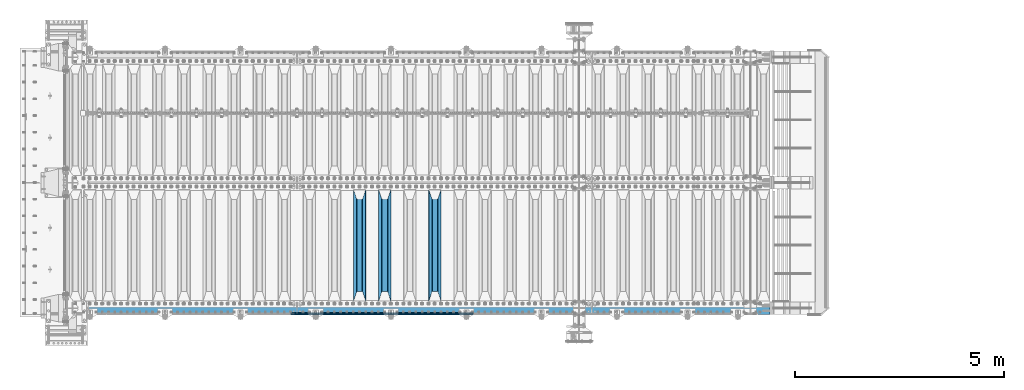
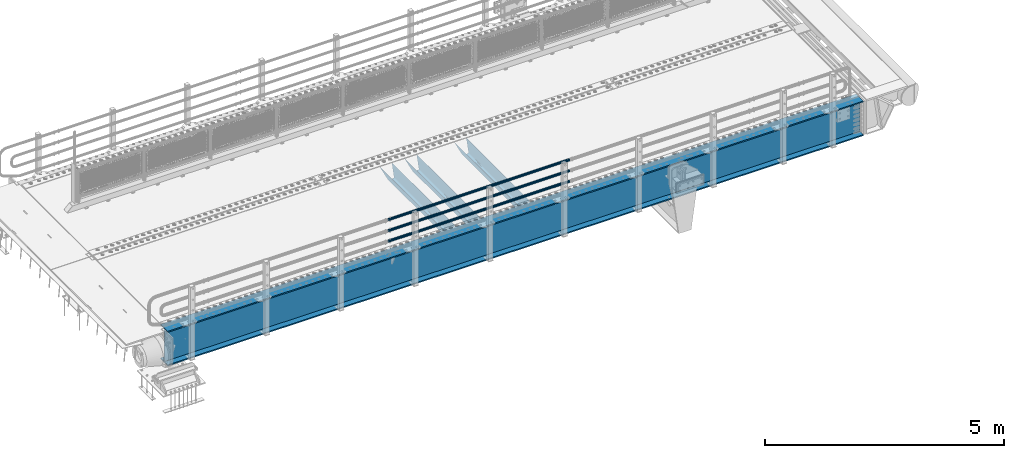
# One storey, part 98 of 208: 7 beams.
"""IFC2X3 building model written with IfcOpenShell, lengths in millimetres."""

from ifc_helpers import new_model, si_unit, frame, origin_with_axes, place, context, subcontext, project, spatial, faceted_brep, material, type_object, element, save


model = new_model("IFC2X3")

# Units and contexts
model_context = context("Model", 3, precision=1e-05, world=origin_with_axes())
body_context = subcontext(model_context, "Body", "Model", "MODEL_VIEW")
ifc_project = project(units=[si_unit("LENGTHUNIT", "METRE", prefix="MILLI"), si_unit("AREAUNIT", "SQUARE_METRE"), si_unit("VOLUMEUNIT", "CUBIC_METRE"), si_unit("MASSUNIT", "GRAM", prefix="KILO"), si_unit("TIMEUNIT", "SECOND"), si_unit("PLANEANGLEUNIT", "RADIAN"), si_unit("SOLIDANGLEUNIT", "STERADIAN"), si_unit("THERMODYNAMICTEMPERATUREUNIT", "DEGREE_CELSIUS"), si_unit("LUMINOUSINTENSITYUNIT", "LUMEN")], contexts=[model_context])

# Site, building, storey
site_placement = place(None, origin_with_axes())
site = spatial("IfcSite", under=ifc_project, at=site_placement, CompositionType="ELEMENT")
building_placement = place(site_placement, origin_with_axes())
building = spatial("IfcBuilding", under=site, at=building_placement, Name="Standard", CompositionType="ELEMENT")
storey_placement = place(building_placement, origin_with_axes())
storey = spatial("IfcBuildingStorey", under=building, at=storey_placement, Name="Undefined", CompositionType="ELEMENT", Elevation=0.0)

# Beams
ifc_material_1 = material(Name="STEEL/S355N")
beam_type_1 = type_object("IfcBeamType", PredefinedType="NOTDEFINED")
beam_1_placement = place(storey_placement, frame((-33650.0, 175.0, -115.0), z_axis=(0.0, 0.0, 1.0), x_axis=(0.0, 1.0, 0.0)))
element("IfcBeam", 1, at=beam_1_placement, inside=storey, type_object=beam_type_1, material=ifc_material_1, context=body_context, shape_type="Brep", body=[
    faceted_brep([(0.0, 150.0, 115.0), (0.0, 143.689999999999, 115.0), (2650.00000000297, 143.689999999999, 115.0), (2650.00000000297, 150.0, 115.0), (2650.00000000297, 142.059565218402, 110.0000000031), (2650.00000000297, 148.369565218403, 110.0000000031), (2441.90079219208, -80.1103600731112, -98.0992078077845), (2437.7588105432, -77.5672621345584, -102.241189456673), (2434.06523489746, -74.4080125315522, -105.934765102404), (2430.91086095089, -70.710272125576, -109.089139048974), (2428.37322971128, -66.5649389910068, -111.626770288588), (2426.51472138055, -62.0739139532889, -113.485278619323), (2425.38102192091, -57.3475956567672, -114.618978078955), (2424.99999999987, -52.5021667386536, -115.0), (2424.99999999987, 52.5021667386536, -115.0), (2425.38102192091, 57.3475956567672, -114.618978078955), (2426.51472138055, 62.0739139532889, -113.485278619323), (2428.37322971128, 66.5649389910068, -111.626770288588), (2430.91086095089, 70.710272125576, -109.089139048974), (2434.06523489746, 74.4080125315522, -105.934765102404), (2437.7588105432, 77.5672621345584, -102.241189456673), (2441.90079219208, 80.1103600731112, -98.0992078077846), (2446.38936140511, 81.9747917625791, -93.6106385947584), (2448.24948500409, 76.2713538057251, -91.7505149957729), (2444.62967112262, 74.76777986261, -95.3703288772456), (2441.28936334126, 72.7168944282894, -98.710636658607), (2438.31067330438, 70.1691124903846, -101.689326695487), (2435.76682334747, 67.1870637758839, -104.233176652398), (2433.72034654133, 63.8440531834895, -106.279653458539), (2432.22154950041, 60.222258798236, -107.778450499454), (2431.30727574265, 56.4107117849089, -108.692724257221), (2430.99999999987, 52.5031078186876, -109.0), (2430.99999999987, -52.5031078186876, -109.0), (2431.30727574265, -56.4107117849089, -108.692724257221), (2432.22154950041, -60.222258798236, -107.778450499454), (2433.72034654133, -63.8440531834895, -106.279653458539), (2435.76682334747, -67.1870637758839, -104.233176652398), (2438.31067330438, -70.1691124903846, -101.689326695487), (2441.28936334126, -72.7168944282894, -98.7106366586071), (2444.62967112262, -74.76777986261, -95.3703288772457), (2448.24948500409, -76.2713538057251, -91.7505149957729), (2650.00000000297, -142.059565218402, 110.0000000031), (2650.00000000297, -148.369565218403, 110.0000000031), (2446.38936140511, -81.9747917625791, -93.6106385947584), (2650.00000000297, -143.689999999999, 115.0), (2650.00000000297, -150.0, 115.0), (0.0, -143.689999999999, 115.0), (0.0, -150.0, 115.0), (0.0, -148.369565218261, 110.000000002663), (203.610638597421, -81.9747917625791, -93.6106385947584), (208.099207810448, -80.1103600731112, -98.0992078077845), (212.241189459336, -77.5672621345584, -102.241189456673), (215.934765105067, -74.4080125315522, -105.934765102404), (219.089139051637, -70.710272125576, -109.089139048974), (221.626770291251, -66.5649389910068, -111.626770288588), (223.485278621986, -62.0739139532889, -113.485278619323), (224.618978081618, -57.3475956567672, -114.618978078955), (225.000000002663, -52.5021667386536, -115.0), (225.000000002663, 52.5021667386536, -115.0), (224.618978081618, 57.3475956567672, -114.618978078955), (223.485278621986, 62.0739139532889, -113.485278619323), (221.626770291251, 66.5649389910068, -111.626770288588), (219.089139051637, 70.710272125576, -109.089139048974), (215.934765105067, 74.4080125315522, -105.934765102404), (212.241189459336, 77.5672621345584, -102.241189456673), (208.099207810448, 80.1103600731112, -98.0992078077846), (203.610638597421, 81.9747917625791, -93.6106385947584), (0.0, 148.369565218261, 110.000000002663), (0.0, 142.05956521826, 110.000000002663), (201.750514998436, 76.2713538057251, -91.7505149957729), (205.370328879908, 74.76777986261, -95.3703288772456), (208.71063666127, 72.7168944282894, -98.710636658607), (211.68932669815, 70.1691124903846, -101.689326695487), (214.233176655061, 67.1870637758839, -104.233176652398), (216.279653461202, 63.8440531834895, -106.279653458539), (217.778450502116, 60.222258798236, -107.778450499454), (218.692724259884, 56.4107117849089, -108.692724257221), (219.000000002663, 52.5031078186876, -109.0), (219.000000002663, -52.5031078186876, -109.0), (218.692724259884, -56.4107117849089, -108.692724257221), (217.778450502116, -60.222258798236, -107.778450499454), (216.279653461202, -63.8440531834895, -106.279653458539), (214.233176655061, -67.1870637758839, -104.233176652398), (211.68932669815, -70.1691124903846, -101.689326695487), (208.71063666127, -72.7168944282894, -98.7106366586071), (205.370328879908, -74.76777986261, -95.3703288772457), (201.750514998436, -76.2713538057251, -91.7505149957729), (0.0, -142.05956521826, 110.000000002663)], [[[0, 1, 2, 3]], [[3, 2, 4, 5]], [[6, 7, 8, 9, 10, 11, 12, 13, 14, 15, 16, 17, 18, 19, 20, 21, 22, 5, 4, 23, 24, 25, 26, 27, 28, 29, 30, 31, 32, 33, 34, 35, 36, 37, 38, 39, 40, 41, 42, 43]], [[44, 45, 42, 41]], [[46, 47, 45, 44]], [[43, 42, 45, 47, 48, 49]], [[6, 43, 49, 50]], [[7, 6, 50, 51]], [[8, 7, 51, 52]], [[9, 8, 52, 53]], [[10, 9, 53, 54]], [[11, 10, 54, 55]], [[12, 11, 55, 56]], [[13, 12, 56, 57]], [[14, 13, 57, 58]], [[15, 14, 58, 59]], [[16, 15, 59, 60]], [[17, 16, 60, 61]], [[18, 17, 61, 62]], [[19, 18, 62, 63]], [[20, 19, 63, 64]], [[21, 20, 64, 65]], [[22, 21, 65, 66]], [[0, 3, 5, 22, 66, 67]], [[1, 0, 67, 68]], [[23, 4, 2, 1, 68, 69]], [[24, 23, 69, 70]], [[25, 24, 70, 71]], [[26, 25, 71, 72]], [[27, 26, 72, 73]], [[28, 27, 73, 74]], [[29, 28, 74, 75]], [[30, 29, 75, 76]], [[31, 30, 76, 77]], [[32, 31, 77, 78]], [[33, 32, 78, 79]], [[34, 33, 79, 80]], [[35, 34, 80, 81]], [[36, 35, 81, 82]], [[37, 36, 82, 83]], [[38, 37, 83, 84]], [[39, 38, 84, 85]], [[40, 39, 85, 86]], [[46, 44, 41, 40, 86, 87]], [[47, 46, 87, 48]], [[86, 85, 84, 83, 82, 81, 80, 79, 78, 77, 76, 75, 74, 73, 72, 71, 70, 69, 68, 67, 66, 65, 64, 63, 62, 61, 60, 59, 58, 57, 56, 55, 54, 53, 52, 51, 50, 49, 48, 87]]]),
])
beam_2_placement = place(storey_placement, frame((-34850.0, 175.0, -115.0), z_axis=(0.0, 0.0, 1.0), x_axis=(0.0, 1.0, 0.0)))
element("IfcBeam", 2, at=beam_2_placement, inside=storey, type_object=beam_type_1, material=ifc_material_1, context=body_context, shape_type="Brep", body=[
    faceted_brep([(0.0, 150.0, 115.0), (0.0, 143.689999999999, 115.0), (2650.00000000297, 143.689999999999, 115.0), (2650.00000000297, 150.0, 115.0), (2650.00000000297, 142.059565218402, 110.0000000031), (2650.00000000297, 148.369565218403, 110.0000000031), (2441.90079219208, -80.1103600731112, -98.0992078077845), (2437.7588105432, -77.5672621345584, -102.241189456673), (2434.06523489746, -74.4080125315522, -105.934765102404), (2430.91086095089, -70.710272125576, -109.089139048974), (2428.37322971128, -66.5649389910068, -111.626770288588), (2426.51472138055, -62.0739139532889, -113.485278619323), (2425.38102192091, -57.3475956567672, -114.618978078955), (2424.99999999987, -52.5021667386536, -115.0), (2424.99999999987, 52.5021667386536, -115.0), (2425.38102192091, 57.3475956567672, -114.618978078955), (2426.51472138055, 62.0739139532889, -113.485278619323), (2428.37322971128, 66.5649389910068, -111.626770288588), (2430.91086095089, 70.710272125576, -109.089139048974), (2434.06523489746, 74.4080125315522, -105.934765102404), (2437.7588105432, 77.5672621345584, -102.241189456673), (2441.90079219208, 80.1103600731112, -98.0992078077846), (2446.38936140511, 81.9747917625791, -93.6106385947584), (2448.24948500409, 76.2713538057251, -91.7505149957729), (2444.62967112262, 74.76777986261, -95.3703288772456), (2441.28936334126, 72.7168944282894, -98.710636658607), (2438.31067330438, 70.1691124903846, -101.689326695487), (2435.76682334747, 67.1870637758839, -104.233176652398), (2433.72034654133, 63.8440531834895, -106.279653458539), (2432.22154950041, 60.222258798236, -107.778450499454), (2431.30727574265, 56.4107117849089, -108.692724257221), (2430.99999999987, 52.5031078186876, -109.0), (2430.99999999987, -52.5031078186876, -109.0), (2431.30727574265, -56.4107117849089, -108.692724257221), (2432.22154950041, -60.222258798236, -107.778450499454), (2433.72034654133, -63.8440531834895, -106.279653458539), (2435.76682334747, -67.1870637758839, -104.233176652398), (2438.31067330438, -70.1691124903846, -101.689326695487), (2441.28936334126, -72.7168944282894, -98.7106366586071), (2444.62967112262, -74.76777986261, -95.3703288772457), (2448.24948500409, -76.2713538057251, -91.7505149957729), (2650.00000000297, -142.059565218402, 110.0000000031), (2650.00000000297, -148.369565218403, 110.0000000031), (2446.38936140511, -81.9747917625791, -93.6106385947584), (2650.00000000297, -143.689999999999, 115.0), (2650.00000000297, -150.0, 115.0), (0.0, -143.689999999999, 115.0), (0.0, -150.0, 115.0), (0.0, -148.369565218261, 110.000000002663), (203.610638597421, -81.9747917625791, -93.6106385947584), (208.099207810448, -80.1103600731112, -98.0992078077845), (212.241189459336, -77.5672621345584, -102.241189456673), (215.934765105067, -74.4080125315522, -105.934765102404), (219.089139051637, -70.710272125576, -109.089139048974), (221.626770291251, -66.5649389910068, -111.626770288588), (223.485278621986, -62.0739139532889, -113.485278619323), (224.618978081618, -57.3475956567672, -114.618978078955), (225.000000002663, -52.5021667386536, -115.0), (225.000000002663, 52.5021667386536, -115.0), (224.618978081618, 57.3475956567672, -114.618978078955), (223.485278621986, 62.0739139532889, -113.485278619323), (221.626770291251, 66.5649389910068, -111.626770288588), (219.089139051637, 70.710272125576, -109.089139048974), (215.934765105067, 74.4080125315522, -105.934765102404), (212.241189459336, 77.5672621345584, -102.241189456673), (208.099207810448, 80.1103600731112, -98.0992078077846), (203.610638597421, 81.9747917625791, -93.6106385947584), (0.0, 148.369565218261, 110.000000002663), (0.0, 142.05956521826, 110.000000002663), (201.750514998436, 76.2713538057251, -91.7505149957729), (205.370328879908, 74.76777986261, -95.3703288772456), (208.71063666127, 72.7168944282894, -98.710636658607), (211.68932669815, 70.1691124903846, -101.689326695487), (214.233176655061, 67.1870637758839, -104.233176652398), (216.279653461202, 63.8440531834895, -106.279653458539), (217.778450502116, 60.222258798236, -107.778450499454), (218.692724259884, 56.4107117849089, -108.692724257221), (219.000000002663, 52.5031078186876, -109.0), (219.000000002663, -52.5031078186876, -109.0), (218.692724259884, -56.4107117849089, -108.692724257221), (217.778450502116, -60.222258798236, -107.778450499454), (216.279653461202, -63.8440531834895, -106.279653458539), (214.233176655061, -67.1870637758839, -104.233176652398), (211.68932669815, -70.1691124903846, -101.689326695487), (208.71063666127, -72.7168944282894, -98.7106366586071), (205.370328879908, -74.76777986261, -95.3703288772457), (201.750514998436, -76.2713538057251, -91.7505149957729), (0.0, -142.05956521826, 110.000000002663)], [[[0, 1, 2, 3]], [[3, 2, 4, 5]], [[6, 7, 8, 9, 10, 11, 12, 13, 14, 15, 16, 17, 18, 19, 20, 21, 22, 5, 4, 23, 24, 25, 26, 27, 28, 29, 30, 31, 32, 33, 34, 35, 36, 37, 38, 39, 40, 41, 42, 43]], [[44, 45, 42, 41]], [[46, 47, 45, 44]], [[43, 42, 45, 47, 48, 49]], [[6, 43, 49, 50]], [[7, 6, 50, 51]], [[8, 7, 51, 52]], [[9, 8, 52, 53]], [[10, 9, 53, 54]], [[11, 10, 54, 55]], [[12, 11, 55, 56]], [[13, 12, 56, 57]], [[14, 13, 57, 58]], [[15, 14, 58, 59]], [[16, 15, 59, 60]], [[17, 16, 60, 61]], [[18, 17, 61, 62]], [[19, 18, 62, 63]], [[20, 19, 63, 64]], [[21, 20, 64, 65]], [[22, 21, 65, 66]], [[0, 3, 5, 22, 66, 67]], [[1, 0, 67, 68]], [[23, 4, 2, 1, 68, 69]], [[24, 23, 69, 70]], [[25, 24, 70, 71]], [[26, 25, 71, 72]], [[27, 26, 72, 73]], [[28, 27, 73, 74]], [[29, 28, 74, 75]], [[30, 29, 75, 76]], [[31, 30, 76, 77]], [[32, 31, 77, 78]], [[33, 32, 78, 79]], [[34, 33, 79, 80]], [[35, 34, 80, 81]], [[36, 35, 81, 82]], [[37, 36, 82, 83]], [[38, 37, 83, 84]], [[39, 38, 84, 85]], [[40, 39, 85, 86]], [[46, 44, 41, 40, 86, 87]], [[47, 46, 87, 48]], [[86, 85, 84, 83, 82, 81, 80, 79, 78, 77, 76, 75, 74, 73, 72, 71, 70, 69, 68, 67, 66, 65, 64, 63, 62, 61, 60, 59, 58, 57, 56, 55, 54, 53, 52, 51, 50, 49, 48, 87]]]),
])
beam_3_placement = place(storey_placement, frame((-35450.0, 175.0, -115.0), z_axis=(0.0, 0.0, 1.0), x_axis=(0.0, 1.0, 0.0)))
element("IfcBeam", 3, at=beam_3_placement, inside=storey, type_object=beam_type_1, material=ifc_material_1, context=body_context, shape_type="Brep", body=[
    faceted_brep([(0.0, 150.0, 115.0), (0.0, 143.689999999999, 115.0), (2650.00000000297, 143.689999999999, 115.0), (2650.00000000297, 150.0, 115.0), (2650.00000000297, 142.059565218402, 110.0000000031), (2650.00000000297, 148.369565218403, 110.0000000031), (2441.90079219208, -80.1103600731112, -98.0992078077845), (2437.7588105432, -77.5672621345584, -102.241189456673), (2434.06523489746, -74.4080125315522, -105.934765102404), (2430.91086095089, -70.710272125576, -109.089139048974), (2428.37322971128, -66.5649389910068, -111.626770288588), (2426.51472138055, -62.0739139532889, -113.485278619323), (2425.38102192091, -57.3475956567672, -114.618978078955), (2424.99999999987, -52.5021667386536, -115.0), (2424.99999999987, 52.5021667386536, -115.0), (2425.38102192091, 57.3475956567672, -114.618978078955), (2426.51472138055, 62.0739139532889, -113.485278619323), (2428.37322971128, 66.5649389910068, -111.626770288588), (2430.91086095089, 70.710272125576, -109.089139048974), (2434.06523489746, 74.4080125315522, -105.934765102404), (2437.7588105432, 77.5672621345584, -102.241189456673), (2441.90079219208, 80.1103600731112, -98.0992078077846), (2446.38936140511, 81.9747917625791, -93.6106385947584), (2448.24948500409, 76.2713538057251, -91.7505149957729), (2444.62967112262, 74.76777986261, -95.3703288772456), (2441.28936334126, 72.7168944282894, -98.710636658607), (2438.31067330438, 70.1691124903846, -101.689326695487), (2435.76682334747, 67.1870637758839, -104.233176652398), (2433.72034654133, 63.8440531834895, -106.279653458539), (2432.22154950041, 60.222258798236, -107.778450499454), (2431.30727574265, 56.4107117849089, -108.692724257221), (2430.99999999987, 52.5031078186876, -109.0), (2430.99999999987, -52.5031078186876, -109.0), (2431.30727574265, -56.4107117849089, -108.692724257221), (2432.22154950041, -60.222258798236, -107.778450499454), (2433.72034654133, -63.8440531834895, -106.279653458539), (2435.76682334747, -67.1870637758839, -104.233176652398), (2438.31067330438, -70.1691124903846, -101.689326695487), (2441.28936334126, -72.7168944282894, -98.7106366586071), (2444.62967112262, -74.76777986261, -95.3703288772457), (2448.24948500409, -76.2713538057251, -91.7505149957729), (2650.00000000297, -142.059565218402, 110.0000000031), (2650.00000000297, -148.369565218403, 110.0000000031), (2446.38936140511, -81.9747917625791, -93.6106385947584), (2650.00000000297, -143.689999999999, 115.0), (2650.00000000297, -150.0, 115.0), (0.0, -143.689999999999, 115.0), (0.0, -150.0, 115.0), (0.0, -148.369565218261, 110.000000002663), (203.610638597421, -81.9747917625791, -93.6106385947584), (208.099207810448, -80.1103600731112, -98.0992078077845), (212.241189459336, -77.5672621345584, -102.241189456673), (215.934765105067, -74.4080125315522, -105.934765102404), (219.089139051637, -70.710272125576, -109.089139048974), (221.626770291251, -66.5649389910068, -111.626770288588), (223.485278621986, -62.0739139532889, -113.485278619323), (224.618978081618, -57.3475956567672, -114.618978078955), (225.000000002663, -52.5021667386536, -115.0), (225.000000002663, 52.5021667386536, -115.0), (224.618978081618, 57.3475956567672, -114.618978078955), (223.485278621986, 62.0739139532889, -113.485278619323), (221.626770291251, 66.5649389910068, -111.626770288588), (219.089139051637, 70.710272125576, -109.089139048974), (215.934765105067, 74.4080125315522, -105.934765102404), (212.241189459336, 77.5672621345584, -102.241189456673), (208.099207810448, 80.1103600731112, -98.0992078077846), (203.610638597421, 81.9747917625791, -93.6106385947584), (0.0, 148.369565218261, 110.000000002663), (0.0, 142.05956521826, 110.000000002663), (201.750514998436, 76.2713538057251, -91.7505149957729), (205.370328879908, 74.76777986261, -95.3703288772456), (208.71063666127, 72.7168944282894, -98.710636658607), (211.68932669815, 70.1691124903846, -101.689326695487), (214.233176655061, 67.1870637758839, -104.233176652398), (216.279653461202, 63.8440531834895, -106.279653458539), (217.778450502116, 60.222258798236, -107.778450499454), (218.692724259884, 56.4107117849089, -108.692724257221), (219.000000002663, 52.5031078186876, -109.0), (219.000000002663, -52.5031078186876, -109.0), (218.692724259884, -56.4107117849089, -108.692724257221), (217.778450502116, -60.222258798236, -107.778450499454), (216.279653461202, -63.8440531834895, -106.279653458539), (214.233176655061, -67.1870637758839, -104.233176652398), (211.68932669815, -70.1691124903846, -101.689326695487), (208.71063666127, -72.7168944282894, -98.7106366586071), (205.370328879908, -74.76777986261, -95.3703288772457), (201.750514998436, -76.2713538057251, -91.7505149957729), (0.0, -142.05956521826, 110.000000002663)], [[[0, 1, 2, 3]], [[3, 2, 4, 5]], [[6, 7, 8, 9, 10, 11, 12, 13, 14, 15, 16, 17, 18, 19, 20, 21, 22, 5, 4, 23, 24, 25, 26, 27, 28, 29, 30, 31, 32, 33, 34, 35, 36, 37, 38, 39, 40, 41, 42, 43]], [[44, 45, 42, 41]], [[46, 47, 45, 44]], [[43, 42, 45, 47, 48, 49]], [[6, 43, 49, 50]], [[7, 6, 50, 51]], [[8, 7, 51, 52]], [[9, 8, 52, 53]], [[10, 9, 53, 54]], [[11, 10, 54, 55]], [[12, 11, 55, 56]], [[13, 12, 56, 57]], [[14, 13, 57, 58]], [[15, 14, 58, 59]], [[16, 15, 59, 60]], [[17, 16, 60, 61]], [[18, 17, 61, 62]], [[19, 18, 62, 63]], [[20, 19, 63, 64]], [[21, 20, 64, 65]], [[22, 21, 65, 66]], [[0, 3, 5, 22, 66, 67]], [[1, 0, 67, 68]], [[23, 4, 2, 1, 68, 69]], [[24, 23, 69, 70]], [[25, 24, 70, 71]], [[26, 25, 71, 72]], [[27, 26, 72, 73]], [[28, 27, 73, 74]], [[29, 28, 74, 75]], [[30, 29, 75, 76]], [[31, 30, 76, 77]], [[32, 31, 77, 78]], [[33, 32, 78, 79]], [[34, 33, 79, 80]], [[35, 34, 80, 81]], [[36, 35, 81, 82]], [[37, 36, 82, 83]], [[38, 37, 83, 84]], [[39, 38, 84, 85]], [[40, 39, 85, 86]], [[46, 44, 41, 40, 86, 87]], [[47, 46, 87, 48]], [[86, 85, 84, 83, 82, 81, 80, 79, 78, 77, 76, 75, 74, 73, 72, 71, 70, 69, 68, 67, 66, 65, 64, 63, 62, 61, 60, 59, 58, 57, 56, 55, 54, 53, 52, 51, 50, 49, 48, 87]]]),
])
ifc_material_2 = material()
beam_type_2 = type_object("IfcBeamType", PredefinedType="NOTDEFINED")
beam_4_placement = place(storey_placement, frame((-32722.0000000001, -129.849999999907, 420.149999999728), z_axis=(0.0, 0.0, -1.0), x_axis=(-1.0, 0.0, 0.0)))
element("IfcBeam", 4, at=beam_4_placement, inside=storey, type_object=beam_type_2, material=ifc_material_2, context=body_context, shape_type="Brep", body=[
    faceted_brep([(0.0, -26.5500000000002, 0.0), (0.0, -24.5290015881747, 10.1602451292931), (4384.00249699992, -24.5290015881747, 10.1602451292931), (4384.00249699992, -26.5500000000002, 0.0), (0.0, -18.7736850405026, 18.7736850405028), (4384.00249699992, -18.7736850405026, 18.7736850405028), (0.0, -10.1602451292929, 24.5290015881747), (4384.00249699992, -10.1602451292929, 24.5290015881747), (0.0, 0.0, 26.55), (4384.00249699992, 0.0, 26.55), (0.0, 10.1602451292929, 24.5290015881747), (4384.00249699992, 10.1602451292929, 24.5290015881747), (0.0, 18.7736850405026, 18.7736850405028), (4384.00249699992, 18.7736850405026, 18.7736850405028), (0.0, 24.5290015881747, 10.1602451292931), (4384.00249699992, 24.5290015881747, 10.1602451292931), (0.0, 26.5500000000002, 0.0), (4384.00249699992, 26.5500000000002, 0.0), (0.0, 24.5290015881747, -10.1602451292931), (4384.00249699992, 24.5290015881747, -10.1602451292931), (0.0, 18.7736850405026, -18.7736850405028), (4384.00249699992, 18.7736850405026, -18.7736850405028), (0.0, 10.1602451292929, -24.5290015881747), (4384.00249699992, 10.1602451292929, -24.5290015881747), (0.0, 0.0, -26.55), (4384.00249699992, 0.0, -26.55), (0.0, -10.1602451292929, -24.5290015881747), (4384.00249699992, -10.1602451292929, -24.5290015881747), (0.0, -18.7736850405026, -18.7736850405028), (4384.00249699992, -18.7736850405026, -18.7736850405028), (0.0, -24.5290015881747, -10.1602451292931), (4384.00249699992, -24.5290015881747, -10.1602451292931), (0.0, -30.1499999999996, 0.0), (0.0, -27.8549679052148, -11.5379054858058), (4384.00249699992, -27.8549679052148, -11.5379054858075), (4384.00249699992, -30.1499999999996, 0.0), (0.0, -21.3192694527743, -21.3192694527752), (4384.00249699992, -21.3192694527743, -21.3192694527744), (0.0, -11.5379054858076, -27.8549679052157), (4384.00249699992, -11.5379054858076, -27.8549679052153), (0.0, 0.0, -30.1500000000015), (4384.00249699992, 0.0, -30.15), (0.0, 11.5379054858076, -27.8549679052157), (4384.00249699992, 11.5379054858076, -27.8549679052153), (0.0, 21.3192694527743, -21.3192694527752), (4384.00249699992, 21.3192694527743, -21.3192694527744), (0.0, 27.8549679052157, -11.5379054858058), (4384.00249699992, 27.8549679052157, -11.5379054858074), (0.0, 30.1499999999996, 0.0), (4384.00249699992, 30.1499999999996, 0.0), (0.0, 27.8549679052157, 11.5379054858058), (4384.00249699992, 27.8549679052157, 11.5379054858075), (0.0, 21.3192694527743, 21.3192694527752), (4384.00249699992, 21.3192694527743, 21.3192694527744), (0.0, 11.5379054858076, 27.8549679052157), (4384.00249699992, 11.5379054858076, 27.8549679052153), (0.0, 0.0, 30.1500000000015), (4384.00249699992, 0.0, 30.15), (0.0, -11.5379054858076, 27.8549679052157), (4384.00249699992, -11.5379054858076, 27.8549679052153), (0.0, -21.3192694527743, 21.3192694527752), (4384.00249699992, -21.3192694527743, 21.3192694527744), (0.0, -27.8549679052157, 11.5379054858058), (4384.00249699992, -27.8549679052157, 11.5379054858075)], [[[0, 1, 2, 3]], [[1, 4, 5, 2]], [[4, 6, 7, 5]], [[6, 8, 9, 7]], [[8, 10, 11, 9]], [[10, 12, 13, 11]], [[12, 14, 15, 13]], [[14, 16, 17, 15]], [[16, 18, 19, 17]], [[18, 20, 21, 19]], [[20, 22, 23, 21]], [[22, 24, 25, 23]], [[24, 26, 27, 25]], [[26, 28, 29, 27]], [[28, 30, 31, 29]], [[30, 0, 3, 31]], [[32, 33, 34, 35]], [[33, 36, 37, 34]], [[36, 38, 39, 37]], [[38, 40, 41, 39]], [[40, 42, 43, 41]], [[42, 44, 45, 43]], [[44, 46, 47, 45]], [[46, 48, 49, 47]], [[48, 50, 51, 49]], [[50, 52, 53, 51]], [[52, 54, 55, 53]], [[54, 56, 57, 55]], [[56, 58, 59, 57]], [[58, 60, 61, 59]], [[60, 62, 63, 61]], [[62, 32, 35, 63]], [[37, 39, 41, 43, 45, 47, 49, 51, 53, 55, 57, 59, 61, 63, 35, 34], [5, 7, 9, 11, 13, 15, 17, 19, 21, 23, 25, 27, 29, 31, 3, 2]], [[62, 60, 58, 56, 54, 52, 50, 48, 46, 44, 42, 40, 38, 36, 33, 32], [30, 28, 26, 24, 22, 20, 18, 16, 14, 12, 10, 8, 6, 4, 1, 0]]]),
])
beam_5_placement = place(storey_placement, frame((-32722.0000000001, -129.849999999907, 969.849999999725), z_axis=(0.0, 0.0, -1.0), x_axis=(-1.0, 0.0, 0.0)))
element("IfcBeam", 5, at=beam_5_placement, inside=storey, type_object=beam_type_2, material=ifc_material_2, context=body_context, shape_type="Brep", body=[
    faceted_brep([(0.0, -26.5500000000002, 0.0), (0.0, -24.5290015881747, 10.1602451292931), (4384.00249699992, -24.5290015881747, 10.1602451292931), (4384.00249699992, -26.5500000000002, 0.0), (0.0, -18.7736850405026, 18.7736850405028), (4384.00249699992, -18.7736850405026, 18.7736850405028), (0.0, -10.1602451292929, 24.5290015881747), (4384.00249699992, -10.1602451292929, 24.5290015881747), (0.0, 0.0, 26.55), (4384.00249699992, 0.0, 26.55), (0.0, 10.1602451292929, 24.5290015881747), (4384.00249699992, 10.1602451292929, 24.5290015881747), (0.0, 18.7736850405026, 18.7736850405028), (4384.00249699992, 18.7736850405026, 18.7736850405028), (0.0, 24.5290015881747, 10.1602451292931), (4384.00249699992, 24.5290015881747, 10.1602451292931), (0.0, 26.5500000000002, 0.0), (4384.00249699992, 26.5500000000002, 0.0), (0.0, 24.5290015881747, -10.1602451292931), (4384.00249699992, 24.5290015881747, -10.1602451292931), (0.0, 18.7736850405026, -18.7736850405028), (4384.00249699992, 18.7736850405026, -18.7736850405028), (0.0, 10.1602451292929, -24.5290015881747), (4384.00249699992, 10.1602451292929, -24.5290015881747), (0.0, 0.0, -26.55), (4384.00249699992, 0.0, -26.55), (0.0, -10.1602451292929, -24.5290015881747), (4384.00249699992, -10.1602451292929, -24.5290015881747), (0.0, -18.7736850405026, -18.7736850405028), (4384.00249699992, -18.7736850405026, -18.7736850405028), (0.0, -24.5290015881747, -10.1602451292931), (4384.00249699992, -24.5290015881747, -10.1602451292931), (0.0, -30.1499999999996, 0.0), (0.0, -27.8549679052148, -11.5379054858058), (4384.00249699992, -27.8549679052148, -11.5379054858075), (4384.00249699992, -30.1499999999996, 0.0), (0.0, -21.3192694527743, -21.3192694527752), (4384.00249699992, -21.3192694527743, -21.3192694527744), (0.0, -11.5379054858076, -27.8549679052157), (4384.00249699992, -11.5379054858076, -27.8549679052153), (0.0, 0.0, -30.1500000000015), (4384.00249699992, 0.0, -30.15), (0.0, 11.5379054858076, -27.8549679052157), (4384.00249699992, 11.5379054858076, -27.8549679052153), (0.0, 21.3192694527743, -21.3192694527752), (4384.00249699992, 21.3192694527743, -21.3192694527744), (0.0, 27.8549679052157, -11.5379054858058), (4384.00249699992, 27.8549679052157, -11.5379054858074), (0.0, 30.1499999999996, 0.0), (4384.00249699992, 30.1499999999996, 0.0), (0.0, 27.8549679052157, 11.5379054858058), (4384.00249699992, 27.8549679052157, 11.5379054858075), (0.0, 21.3192694527743, 21.3192694527752), (4384.00249699992, 21.3192694527743, 21.3192694527744), (0.0, 11.5379054858076, 27.8549679052157), (4384.00249699992, 11.5379054858076, 27.8549679052153), (0.0, 0.0, 30.1500000000015), (4384.00249699992, 0.0, 30.15), (0.0, -11.5379054858076, 27.8549679052157), (4384.00249699992, -11.5379054858076, 27.8549679052153), (0.0, -21.3192694527743, 21.3192694527752), (4384.00249699992, -21.3192694527743, 21.3192694527744), (0.0, -27.8549679052157, 11.5379054858058), (4384.00249699992, -27.8549679052157, 11.5379054858075)], [[[0, 1, 2, 3]], [[1, 4, 5, 2]], [[4, 6, 7, 5]], [[6, 8, 9, 7]], [[8, 10, 11, 9]], [[10, 12, 13, 11]], [[12, 14, 15, 13]], [[14, 16, 17, 15]], [[16, 18, 19, 17]], [[18, 20, 21, 19]], [[20, 22, 23, 21]], [[22, 24, 25, 23]], [[24, 26, 27, 25]], [[26, 28, 29, 27]], [[28, 30, 31, 29]], [[30, 0, 3, 31]], [[32, 33, 34, 35]], [[33, 36, 37, 34]], [[36, 38, 39, 37]], [[38, 40, 41, 39]], [[40, 42, 43, 41]], [[42, 44, 45, 43]], [[44, 46, 47, 45]], [[46, 48, 49, 47]], [[48, 50, 51, 49]], [[50, 52, 53, 51]], [[52, 54, 55, 53]], [[54, 56, 57, 55]], [[56, 58, 59, 57]], [[58, 60, 61, 59]], [[60, 62, 63, 61]], [[62, 32, 35, 63]], [[37, 39, 41, 43, 45, 47, 49, 51, 53, 55, 57, 59, 61, 63, 35, 34], [5, 7, 9, 11, 13, 15, 17, 19, 21, 23, 25, 27, 29, 31, 3, 2]], [[62, 60, 58, 56, 54, 52, 50, 48, 46, 44, 42, 40, 38, 36, 33, 32], [30, 28, 26, 24, 22, 20, 18, 16, 14, 12, 10, 8, 6, 4, 1, 0]]]),
])
beam_6_placement = place(storey_placement, frame((-32722.0000000001, -129.849999999907, 689.849999999725), z_axis=(0.0, 0.0, -1.0), x_axis=(-1.0, 0.0, 0.0)))
element("IfcBeam", 6, at=beam_6_placement, inside=storey, type_object=beam_type_2, material=ifc_material_2, context=body_context, shape_type="Brep", body=[
    faceted_brep([(0.0, -26.5500000000002, 0.0), (0.0, -24.5290015881747, 10.1602451292931), (4384.00249699992, -24.5290015881747, 10.1602451292931), (4384.00249699992, -26.5500000000002, 0.0), (0.0, -18.7736850405026, 18.7736850405028), (4384.00249699992, -18.7736850405026, 18.7736850405028), (0.0, -10.1602451292929, 24.5290015881747), (4384.00249699992, -10.1602451292929, 24.5290015881747), (0.0, 0.0, 26.55), (4384.00249699992, 0.0, 26.55), (0.0, 10.1602451292929, 24.5290015881747), (4384.00249699992, 10.1602451292929, 24.5290015881747), (0.0, 18.7736850405026, 18.7736850405028), (4384.00249699992, 18.7736850405026, 18.7736850405028), (0.0, 24.5290015881747, 10.1602451292931), (4384.00249699992, 24.5290015881747, 10.1602451292931), (0.0, 26.5500000000002, 0.0), (4384.00249699992, 26.5500000000002, 0.0), (0.0, 24.5290015881747, -10.1602451292931), (4384.00249699992, 24.5290015881747, -10.1602451292931), (0.0, 18.7736850405026, -18.7736850405028), (4384.00249699992, 18.7736850405026, -18.7736850405028), (0.0, 10.1602451292929, -24.5290015881747), (4384.00249699992, 10.1602451292929, -24.5290015881747), (0.0, 0.0, -26.55), (4384.00249699992, 0.0, -26.55), (0.0, -10.1602451292929, -24.5290015881747), (4384.00249699992, -10.1602451292929, -24.5290015881747), (0.0, -18.7736850405026, -18.7736850405028), (4384.00249699992, -18.7736850405026, -18.7736850405028), (0.0, -24.5290015881747, -10.1602451292931), (4384.00249699992, -24.5290015881747, -10.1602451292931), (0.0, -30.1499999999996, 0.0), (0.0, -27.8549679052148, -11.5379054858058), (4384.00249699992, -27.8549679052148, -11.5379054858075), (4384.00249699992, -30.1499999999996, 0.0), (0.0, -21.3192694527743, -21.3192694527752), (4384.00249699992, -21.3192694527743, -21.3192694527744), (0.0, -11.5379054858076, -27.8549679052157), (4384.00249699992, -11.5379054858076, -27.8549679052153), (0.0, 0.0, -30.1500000000015), (4384.00249699992, 0.0, -30.15), (0.0, 11.5379054858076, -27.8549679052157), (4384.00249699992, 11.5379054858076, -27.8549679052153), (0.0, 21.3192694527743, -21.3192694527752), (4384.00249699992, 21.3192694527743, -21.3192694527744), (0.0, 27.8549679052157, -11.5379054858058), (4384.00249699992, 27.8549679052157, -11.5379054858074), (0.0, 30.1499999999996, 0.0), (4384.00249699992, 30.1499999999996, 0.0), (0.0, 27.8549679052157, 11.5379054858058), (4384.00249699992, 27.8549679052157, 11.5379054858075), (0.0, 21.3192694527743, 21.3192694527752), (4384.00249699992, 21.3192694527743, 21.3192694527744), (0.0, 11.5379054858076, 27.8549679052157), (4384.00249699992, 11.5379054858076, 27.8549679052153), (0.0, 0.0, 30.1500000000015), (4384.00249699992, 0.0, 30.15), (0.0, -11.5379054858076, 27.8549679052157), (4384.00249699992, -11.5379054858076, 27.8549679052153), (0.0, -21.3192694527743, 21.3192694527752), (4384.00249699992, -21.3192694527743, 21.3192694527744), (0.0, -27.8549679052157, 11.5379054858058), (4384.00249699992, -27.8549679052157, 11.5379054858075)], [[[0, 1, 2, 3]], [[1, 4, 5, 2]], [[4, 6, 7, 5]], [[6, 8, 9, 7]], [[8, 10, 11, 9]], [[10, 12, 13, 11]], [[12, 14, 15, 13]], [[14, 16, 17, 15]], [[16, 18, 19, 17]], [[18, 20, 21, 19]], [[20, 22, 23, 21]], [[22, 24, 25, 23]], [[24, 26, 27, 25]], [[26, 28, 29, 27]], [[28, 30, 31, 29]], [[30, 0, 3, 31]], [[32, 33, 34, 35]], [[33, 36, 37, 34]], [[36, 38, 39, 37]], [[38, 40, 41, 39]], [[40, 42, 43, 41]], [[42, 44, 45, 43]], [[44, 46, 47, 45]], [[46, 48, 49, 47]], [[48, 50, 51, 49]], [[50, 52, 53, 51]], [[52, 54, 55, 53]], [[54, 56, 57, 55]], [[56, 58, 59, 57]], [[58, 60, 61, 59]], [[60, 62, 63, 61]], [[62, 32, 35, 63]], [[37, 39, 41, 43, 45, 47, 49, 51, 53, 55, 57, 59, 61, 63, 35, 34], [5, 7, 9, 11, 13, 15, 17, 19, 21, 23, 25, 27, 29, 31, 3, 2]], [[62, 60, 58, 56, 54, 52, 50, 48, 46, 44, 42, 40, 38, 36, 33, 32], [30, 28, 26, 24, 22, 20, 18, 16, 14, 12, 10, 8, 6, 4, 1, 0]]]),
])
beam_type_3 = type_object("IfcBeamType", Name="HEA900", PredefinedType="NOTDEFINED")
beam_7_placement = place(storey_placement, frame((-42440.0, 0.0, -445.0), z_axis=(0.0, 0.0, 1.0), x_axis=(1.0, 0.0, 0.0)))
element("IfcBeam", 7, at=beam_7_placement, inside=storey, type_object=beam_type_3, material=ifc_material_1, ObjectType="HEA900", context=body_context, shape_type="Brep", body=[
    faceted_brep([(0.0, 150.0, -445.0), (0.0, 150.0, -415.0), (16807.0, 150.0, -415.0), (16807.0, 150.0, -445.0), (0.0, 8.0, -415.0), (16807.0, 8.0, -415.0), (0.0, 8.0, 415.0), (16807.0, 8.0, 415.0), (0.0, 150.0, 415.0), (16807.0, 150.0, 415.0), (0.0, 150.0, 445.0), (16807.0, 150.0, 445.0), (0.0, -150.0, 445.0), (16807.0, -150.0, 445.0), (0.0, -150.0, 415.0), (16807.0, -150.0, 415.0), (0.0, -8.0, 415.0), (16807.0, -8.0, 415.0), (0.0, -8.0, -415.0), (16807.0, -8.0, -415.0), (0.0, -150.0, -415.0), (16807.0, -150.0, -415.0), (0.0, -150.0, -445.0), (16807.0, -150.0, -445.0)], [[[0, 1, 2, 3]], [[1, 4, 5, 2]], [[4, 6, 7, 5]], [[6, 8, 9, 7]], [[8, 10, 11, 9]], [[10, 12, 13, 11]], [[12, 14, 15, 13]], [[14, 16, 17, 15]], [[16, 18, 19, 17]], [[18, 20, 21, 19]], [[20, 22, 23, 21]], [[22, 0, 3, 23]], [[5, 7, 9, 11, 13, 15, 17, 19, 21, 23, 3, 2]], [[22, 20, 18, 16, 14, 12, 10, 8, 6, 4, 1, 0]]]),
])

save(model, "model.ifc")
